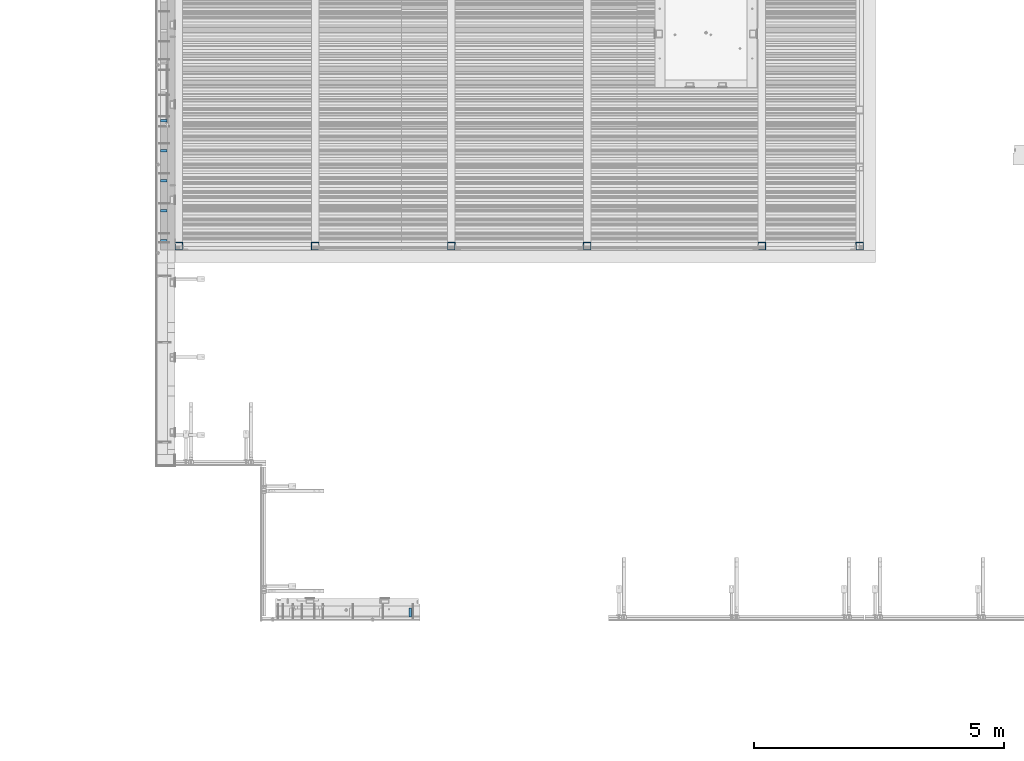
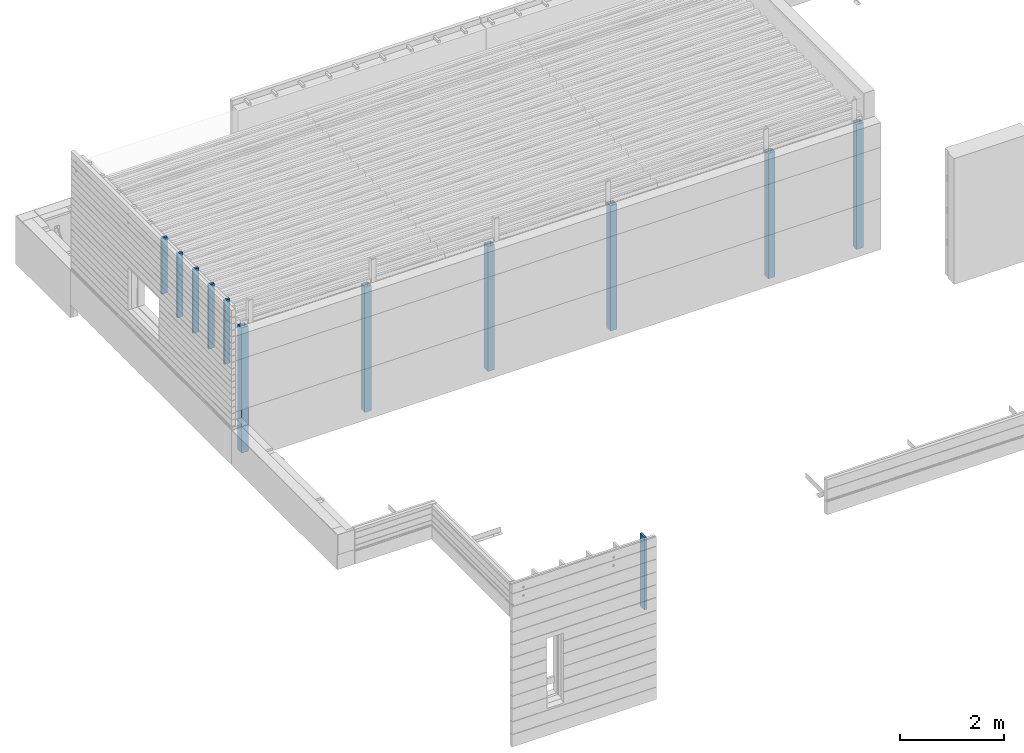
# One storey, part 2 of 153: 12 columns, 8 elements without a shape of their own.
"""IFC2X3 building model written with IfcOpenShell, lengths in millimetres."""

from ifc_helpers import new_model, si_unit, frame, origin_with_axes, place, context, subcontext, project, spatial, faceted_brep, material, type_object, element, aggregate, save


model = new_model("IFC2X3")

# Units and contexts
model_context = context("Model", 3, precision=1e-05, world=origin_with_axes())
body_context = subcontext(model_context, "Body", "Model", "MODEL_VIEW")
ifc_project = project(units=[si_unit("LENGTHUNIT", "METRE", prefix="MILLI"), si_unit("AREAUNIT", "SQUARE_METRE"), si_unit("VOLUMEUNIT", "CUBIC_METRE"), si_unit("MASSUNIT", "GRAM", prefix="KILO"), si_unit("TIMEUNIT", "SECOND"), si_unit("PLANEANGLEUNIT", "RADIAN"), si_unit("SOLIDANGLEUNIT", "STERADIAN"), si_unit("THERMODYNAMICTEMPERATUREUNIT", "DEGREE_CELSIUS"), si_unit("LUMINOUSINTENSITYUNIT", "LUMEN")], contexts=[model_context])

# Site, building, storey
site_placement = place(None, origin_with_axes())
site = spatial("IfcSite", under=ifc_project, at=site_placement, CompositionType="ELEMENT")
building_placement = place(site_placement, origin_with_axes())
building = spatial("IfcBuilding", under=site, at=building_placement, CompositionType="ELEMENT")
storey_placement = place(building_placement, origin_with_axes())
storey = spatial("IfcBuildingStorey", under=building, at=storey_placement, Name="8", CompositionType="ELEMENT", Elevation=0.0)

# Assembly, column
assembly_1_placement = place(storey_placement, origin_with_axes())
assembly_1 = element("IfcElementAssembly", 1, at=assembly_1_placement, inside=storey, Name="Steel Assembly", AssemblyPlace="NOTDEFINED", PredefinedType="RIGID_FRAME")
ifc_material_1 = material(Name="STEEL/S355J2")
column_type_1 = type_object("IfcColumnType", Name="150X150X5", PredefinedType="NOTDEFINED")
column_1_placement = place(assembly_1_placement, frame((16252.0, 15055.0, 102730.0), z_axis=(0.0, 1.0, 0.0), x_axis=(0.0, 0.0, 1.0)))
column_1 = element("IfcColumn", 2, at=column_1_placement, type_object=column_type_1, material=ifc_material_1, Name="COLUMN", ObjectType="150X150X5", context=body_context, shape_type="Brep", body=[
    faceted_brep([(0.0, 70.0, -70.0), (0.0, -70.0, -70.0), (2935.0, -70.0, -70.0), (2935.0, 70.0, -70.0), (0.0, -70.0, 70.0), (2935.0, -70.0, 70.0), (0.0, 70.0, 70.0), (2935.0, 70.0, 70.0), (0.0, 75.0, -75.0), (0.0, 75.0, 75.0), (2935.0, 75.0, 75.0), (2935.0, 75.0, -75.0), (0.0, -75.0, 75.0), (2935.0, -75.0, 75.0), (0.0, -75.0, -75.0), (2935.0, -75.0, -75.0)], [[[0, 1, 2, 3]], [[1, 4, 5, 2]], [[4, 6, 7, 5]], [[6, 0, 3, 7]], [[8, 9, 10, 11]], [[9, 12, 13, 10]], [[12, 14, 15, 13]], [[14, 8, 11, 15]], [[13, 15, 11, 10], [5, 7, 3, 2]], [[14, 12, 9, 8], [6, 4, 1, 0]]]),
])
aggregate(assembly_1, [column_1])

assembly_2_placement = place(storey_placement, origin_with_axes())
assembly_2 = element("IfcElementAssembly", 3, at=assembly_2_placement, inside=storey, Name="Steel Assembly", AssemblyPlace="NOTDEFINED", PredefinedType="RIGID_FRAME")
column_2_placement = place(assembly_2_placement, frame((19752.0, 15055.0, 102730.0), z_axis=(0.0, 1.0, 0.0), x_axis=(0.0, 0.0, 1.0)))
column_2 = element("IfcColumn", 4, at=column_2_placement, type_object=column_type_1, material=ifc_material_1, Name="COLUMN", ObjectType="150X150X5", context=body_context, shape_type="Brep", body=[
    faceted_brep([(0.0, 70.0, -70.0), (0.0, -70.0, -70.0), (2935.0, -70.0, -70.0), (2935.0, 70.0, -70.0), (0.0, -70.0, 70.0), (2935.0, -70.0, 70.0), (0.0, 70.0, 70.0), (2935.0, 70.0, 70.0), (0.0, 75.0, -75.0), (0.0, 75.0, 75.0), (2935.0, 75.0, 75.0), (2935.0, 75.0, -75.0), (0.0, -75.0, 75.0), (2935.0, -75.0, 75.0), (0.0, -75.0, -75.0), (2935.0, -75.0, -75.0)], [[[0, 1, 2, 3]], [[1, 4, 5, 2]], [[4, 6, 7, 5]], [[6, 0, 3, 7]], [[8, 9, 10, 11]], [[9, 12, 13, 10]], [[12, 14, 15, 13]], [[14, 8, 11, 15]], [[13, 15, 11, 10], [5, 7, 3, 2]], [[14, 12, 9, 8], [6, 4, 1, 0]]]),
])
aggregate(assembly_2, [column_2])

assembly_3_placement = place(storey_placement, origin_with_axes())
assembly_3 = element("IfcElementAssembly", 5, at=assembly_3_placement, inside=storey, Name="Steel Assembly", AssemblyPlace="NOTDEFINED", PredefinedType="RIGID_FRAME")
column_3_placement = place(assembly_3_placement, frame((21712.0, 15055.0, 102730.0), z_axis=(0.0, 1.0, 0.0), x_axis=(0.0, 0.0, 1.0)))
column_3 = element("IfcColumn", 6, at=column_3_placement, type_object=column_type_1, material=ifc_material_1, Name="COLUMN", ObjectType="150X150X5", context=body_context, shape_type="Brep", body=[
    faceted_brep([(0.0, 70.0, -70.0), (0.0, -70.0, -70.0), (2935.0, -70.0, -70.0), (2935.0, 70.0, -70.0), (0.0, -70.0, 70.0), (2935.0, -70.0, 70.0), (0.0, 70.0, 70.0), (2935.0, 70.0, 70.0), (0.0, 75.0, -75.0), (0.0, 75.0, 75.0), (2935.0, 75.0, 75.0), (2935.0, 75.0, -75.0), (0.0, -75.0, 75.0), (2935.0, -75.0, 75.0), (0.0, -75.0, -75.0), (2935.0, -75.0, -75.0)], [[[0, 1, 2, 3]], [[1, 4, 5, 2]], [[4, 6, 7, 5]], [[6, 0, 3, 7]], [[8, 9, 10, 11]], [[9, 12, 13, 10]], [[12, 14, 15, 13]], [[14, 8, 11, 15]], [[13, 15, 11, 10], [5, 7, 3, 2]], [[14, 12, 9, 8], [6, 4, 1, 0]]]),
])
aggregate(assembly_3, [column_3])

assembly_4_placement = place(storey_placement, origin_with_axes())
assembly_4 = element("IfcElementAssembly", 7, at=assembly_4_placement, inside=storey, Name="Steel Assembly", AssemblyPlace="NOTDEFINED", PredefinedType="RIGID_FRAME")
column_4_placement = place(assembly_4_placement, frame((13535.0, 15055.0, 102730.0), z_axis=(0.0, 1.0, 0.0), x_axis=(0.0, 0.0, 1.0)))
column_4 = element("IfcColumn", 8, at=column_4_placement, type_object=column_type_1, material=ifc_material_1, Name="COLUMN", ObjectType="150X150X5", context=body_context, shape_type="Brep", body=[
    faceted_brep([(0.0, 70.0, -70.0), (0.0, -70.0, -70.0), (2935.0, -70.0, -70.0), (2935.0, 70.0, -70.0), (0.0, -70.0, 70.0), (2935.0, -70.0, 70.0), (0.0, 70.0, 70.0), (2935.0, 70.0, 70.0), (0.0, 75.0, -75.0), (0.0, 75.0, 75.0), (2935.0, 75.0, 75.0), (2935.0, 75.0, -75.0), (0.0, -75.0, 75.0), (2935.0, -75.0, 75.0), (0.0, -75.0, -75.0), (2935.0, -75.0, -75.0)], [[[0, 1, 2, 3]], [[1, 4, 5, 2]], [[4, 6, 7, 5]], [[6, 0, 3, 7]], [[8, 9, 10, 11]], [[9, 12, 13, 10]], [[12, 14, 15, 13]], [[14, 8, 11, 15]], [[13, 15, 11, 10], [5, 7, 3, 2]], [[14, 12, 9, 8], [6, 4, 1, 0]]]),
])
aggregate(assembly_4, [column_4])

assembly_5_placement = place(storey_placement, origin_with_axes())
assembly_5 = element("IfcElementAssembly", 9, at=assembly_5_placement, inside=storey, Name="Steel Assembly", AssemblyPlace="NOTDEFINED", PredefinedType="RIGID_FRAME")
column_5_placement = place(assembly_5_placement, frame((10805.0, 15055.0, 102730.0), z_axis=(0.0, 1.0, 0.0), x_axis=(0.0, 0.0, 1.0)))
column_5 = element("IfcColumn", 10, at=column_5_placement, type_object=column_type_1, material=ifc_material_1, Name="COLUMN", ObjectType="150X150X5", context=body_context, shape_type="Brep", body=[
    faceted_brep([(0.0, 70.0, -70.0), (0.0, -70.0, -70.0), (2935.0, -70.0, -70.0), (2935.0, 70.0, -70.0), (0.0, -70.0, 70.0), (2935.0, -70.0, 70.0), (0.0, 70.0, 70.0), (2935.0, 70.0, 70.0), (0.0, 75.0, -75.0), (0.0, 75.0, 75.0), (2935.0, 75.0, 75.0), (2935.0, 75.0, -75.0), (0.0, -75.0, 75.0), (2935.0, -75.0, 75.0), (0.0, -75.0, -75.0), (2935.0, -75.0, -75.0)], [[[0, 1, 2, 3]], [[1, 4, 5, 2]], [[4, 6, 7, 5]], [[6, 0, 3, 7]], [[8, 9, 10, 11]], [[9, 12, 13, 10]], [[12, 14, 15, 13]], [[14, 8, 11, 15]], [[13, 15, 11, 10], [5, 7, 3, 2]], [[14, 12, 9, 8], [6, 4, 1, 0]]]),
])
aggregate(assembly_5, [column_5])

assembly_6_placement = place(storey_placement, origin_with_axes())
assembly_6 = element("IfcElementAssembly", 11, at=assembly_6_placement, inside=storey, Name="Steel Assembly", AssemblyPlace="NOTDEFINED", PredefinedType="RIGID_FRAME")
column_6_placement = place(assembly_6_placement, frame((8075.0, 15055.0, 102730.0), z_axis=(0.0, 1.0, 0.0), x_axis=(0.0, 0.0, 1.0)))
column_6 = element("IfcColumn", 12, at=column_6_placement, type_object=column_type_1, material=ifc_material_1, Name="COLUMN", ObjectType="150X150X5", context=body_context, shape_type="Brep", body=[
    faceted_brep([(0.0, 70.0, -70.0), (0.0, -70.0, -70.0), (2935.0, -70.0, -70.0), (2935.0, 70.0, -70.0), (0.0, -70.0, 70.0), (2935.0, -70.0, 70.0), (0.0, 70.0, 70.0), (2935.0, 70.0, 70.0), (0.0, 75.0, -75.0), (0.0, 75.0, 75.0), (2935.0, 75.0, 75.0), (2935.0, 75.0, -75.0), (0.0, -75.0, 75.0), (2935.0, -75.0, 75.0), (0.0, -75.0, -75.0), (2935.0, -75.0, -75.0)], [[[0, 1, 2, 3]], [[1, 4, 5, 2]], [[4, 6, 7, 5]], [[6, 0, 3, 7]], [[8, 9, 10, 11]], [[9, 12, 13, 10]], [[12, 14, 15, 13]], [[14, 8, 11, 15]], [[13, 15, 11, 10], [5, 7, 3, 2]], [[14, 12, 9, 8], [6, 4, 1, 0]]]),
])
aggregate(assembly_6, [column_6])

# Assembly, columns
assembly_7_placement = place(storey_placement, origin_with_axes())
assembly_7 = element("IfcElementAssembly", 13, at=assembly_7_placement, inside=storey, AssemblyPlace="NOTDEFINED", PredefinedType="REINFORCEMENT_UNIT")
ifc_material_2 = material(Name="TIMBER/T24")
column_type_2 = type_object("IfcColumnType", Name="PK50X125", PredefinedType="NOTDEFINED")
column_7_placement = place(assembly_7_placement, frame((7772.49680351058, 15165.0, 104810.0), z_axis=(1.0, 0.0, 0.0), x_axis=(0.0, 0.0, 1.0)))
column_7 = element("IfcColumn", 14, at=column_7_placement, type_object=column_type_2, material=ifc_material_2, ObjectType="PK50X125", context=body_context, shape_type="Brep", body=[
    faceted_brep([(0.0, 25.0, 62.5), (0.0, -25.0, 62.5), (1505.0, -25.0, 62.5), (1505.0, 25.0, 62.5), (0.0, -25.0, -62.5), (1505.0, -25.0, -62.5), (0.0, 25.0, -62.5), (1505.0, 25.0, -62.5)], [[[0, 1, 2, 3]], [[1, 4, 5, 2]], [[4, 6, 7, 5]], [[6, 0, 3, 7]], [[5, 7, 3, 2]], [[6, 4, 1, 0]]]),
])
column_8_placement = place(assembly_7_placement, frame((7772.49680351058, 15765.0, 104810.0), z_axis=(1.0, 0.0, 0.0), x_axis=(0.0, 0.0, 1.0)))
column_8 = element("IfcColumn", 15, at=column_8_placement, type_object=column_type_2, material=ifc_material_2, ObjectType="PK50X125", context=body_context, shape_type="Brep", body=[
    faceted_brep([(0.0, 25.0, 62.5), (0.0, -25.0, 62.5), (1505.0, -25.0, 62.5), (1505.0, 25.0, 62.5), (0.0, -25.0, -62.5), (1505.0, -25.0, -62.5), (0.0, 25.0, -62.5), (1505.0, 25.0, -62.5)], [[[0, 1, 2, 3]], [[1, 4, 5, 2]], [[4, 6, 7, 5]], [[6, 0, 3, 7]], [[5, 7, 3, 2]], [[6, 4, 1, 0]]]),
])
column_9_placement = place(assembly_7_placement, frame((7772.49680351058, 16365.0, 104810.0), z_axis=(1.0, 0.0, 0.0), x_axis=(0.0, 0.0, 1.0)))
column_9 = element("IfcColumn", 16, at=column_9_placement, type_object=column_type_2, material=ifc_material_2, ObjectType="PK50X125", context=body_context, shape_type="Brep", body=[
    faceted_brep([(0.0, 25.0, 62.5), (0.0, -25.0, 62.5), (1505.0, -25.0, 62.5), (1505.0, 25.0, 62.5), (0.0, -25.0, -62.5), (1505.0, -25.0, -62.5), (0.0, 25.0, -62.5), (1505.0, 25.0, -62.5)], [[[0, 1, 2, 3]], [[1, 4, 5, 2]], [[4, 6, 7, 5]], [[6, 0, 3, 7]], [[5, 7, 3, 2]], [[6, 4, 1, 0]]]),
])
column_10_placement = place(assembly_7_placement, frame((7772.49680351058, 16965.0, 104810.0), z_axis=(1.0, 0.0, 0.0), x_axis=(0.0, 0.0, 1.0)))
column_10 = element("IfcColumn", 17, at=column_10_placement, type_object=column_type_2, material=ifc_material_2, ObjectType="PK50X125", context=body_context, shape_type="Brep", body=[
    faceted_brep([(0.0, 25.0, 62.5), (0.0, -25.0, 62.5), (1505.0, -25.0, 62.5), (1505.0, 25.0, 62.5), (0.0, -25.0, -62.5), (1505.0, -25.0, -62.5), (0.0, 25.0, -62.5), (1505.0, 25.0, -62.5)], [[[0, 1, 2, 3]], [[1, 4, 5, 2]], [[4, 6, 7, 5]], [[6, 0, 3, 7]], [[5, 7, 3, 2]], [[6, 4, 1, 0]]]),
])
column_11_placement = place(assembly_7_placement, frame((7772.49680351058, 17565.0, 105004.0), z_axis=(1.0, 0.0, 0.0), x_axis=(0.0, 0.0, 1.0)))
column_11 = element("IfcColumn", 18, at=column_11_placement, type_object=column_type_2, material=ifc_material_2, ObjectType="PK50X125", context=body_context, shape_type="Brep", body=[
    faceted_brep([(0.0, 25.0, 62.5), (0.0, -25.0, 62.5), (1311.0, -25.0, 62.5), (1311.0, 25.0, 62.5), (0.0, -25.0, -62.5), (1311.0, -25.0, -62.5), (0.0, 25.0, -62.5), (1311.0, 25.0, -62.5)], [[[0, 1, 2, 3]], [[1, 4, 5, 2]], [[4, 6, 7, 5]], [[6, 0, 3, 7]], [[5, 7, 3, 2]], [[6, 4, 1, 0]]]),
])
aggregate(assembly_7, [column_7, column_8, column_9, column_10, column_11])

# Assembly, column
assembly_8_placement = place(storey_placement, origin_with_axes())
assembly_8 = element("IfcElementAssembly", 19, at=assembly_8_placement, inside=storey, AssemblyPlace="NOTDEFINED", PredefinedType="REINFORCEMENT_UNIT")
column_type_3 = type_object("IfcColumnType", Name="PK50X175", PredefinedType="NOTDEFINED")
column_12_placement = place(assembly_8_placement, frame((12715.0, 7717.5, 101870.0), z_axis=(0.0, 1.0, 0.0), x_axis=(0.0, 0.0, 1.0)))
column_12 = element("IfcColumn", 20, at=column_12_placement, type_object=column_type_3, material=ifc_material_2, ObjectType="PK50X175", context=body_context, shape_type="Brep", body=[
    faceted_brep([(0.0, 25.0, 87.5), (0.0, -25.0, 87.5), (1700.0, -25.0, 87.5), (1700.0, 25.0, 87.5), (0.0, -25.0, -87.5), (1700.0, -25.0, -87.5), (0.0, 25.0, -87.5), (1700.0, 25.0, -87.5)], [[[0, 1, 2, 3]], [[1, 4, 5, 2]], [[4, 6, 7, 5]], [[6, 0, 3, 7]], [[5, 7, 3, 2]], [[6, 4, 1, 0]]]),
])
aggregate(assembly_8, [column_12])

save(model, "model.ifc")
